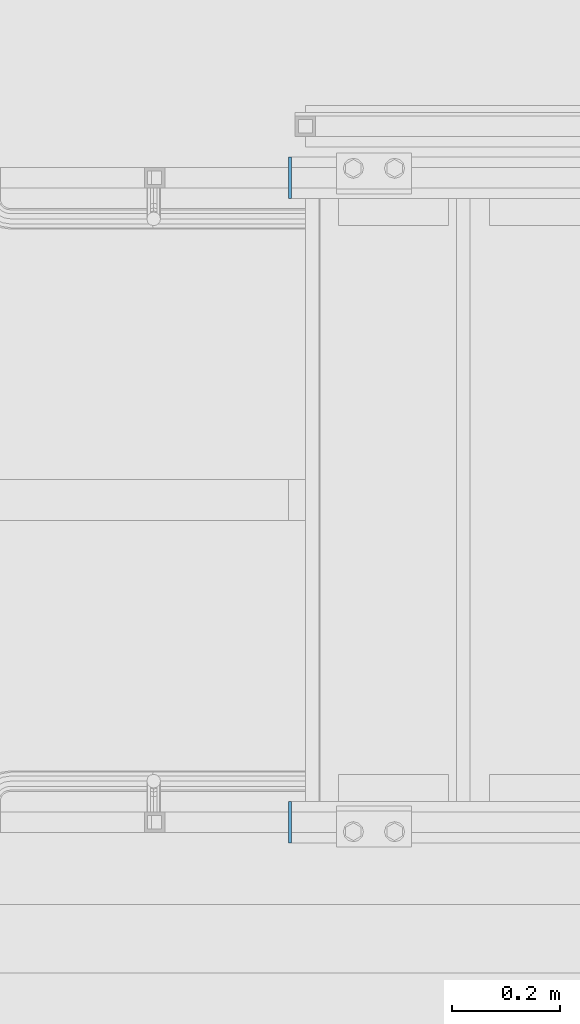
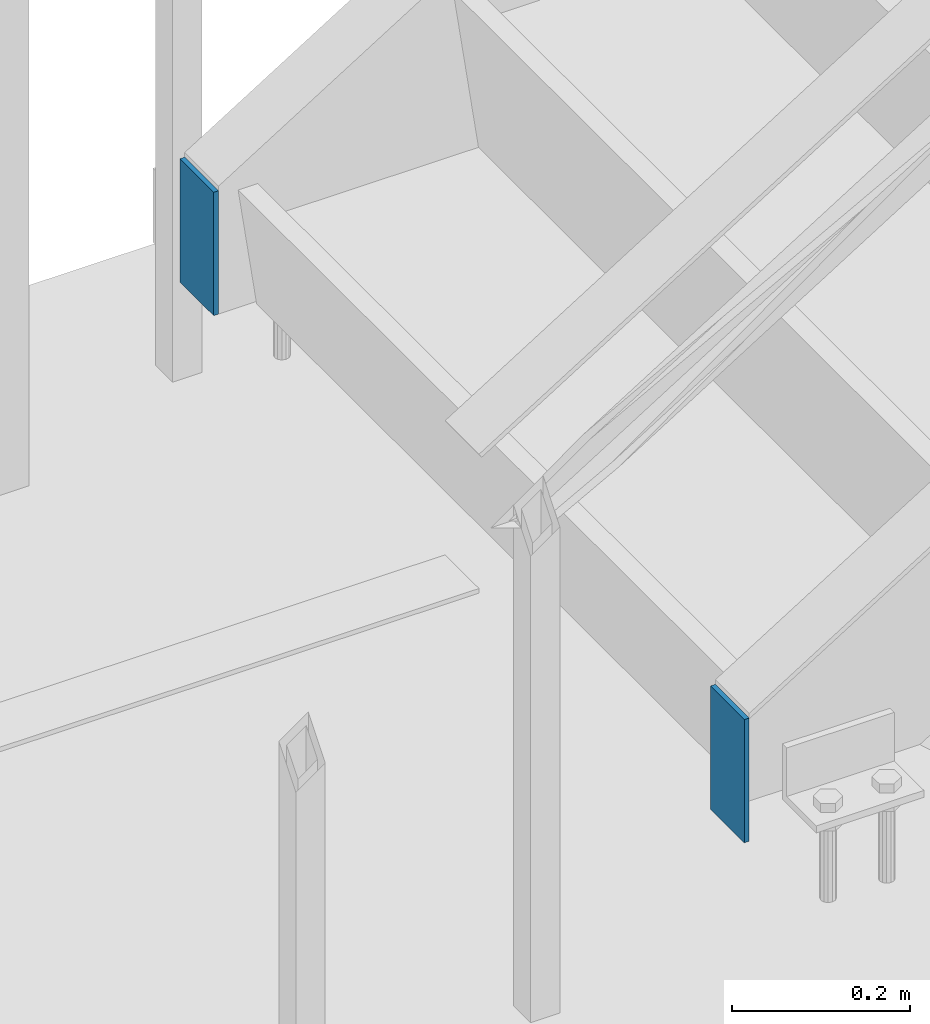
# One storey, part 1571 of 3843: 2 columns, 1 element without a shape of its own.
"""IFC2X3 building model written with IfcOpenShell, lengths in millimetres."""

from ifc_helpers import new_model, si_unit, frame, origin_with_axes, place, context, subcontext, project, spatial, faceted_brep, material, type_object, element, aggregate, save


model = new_model("IFC2X3")

# Units and contexts
model_context = context("Model", 3, precision=1e-05, world=origin_with_axes())
body_context = subcontext(model_context, "Body", "Model", "MODEL_VIEW")
ifc_project = project(units=[si_unit("LENGTHUNIT", "METRE", prefix="MILLI"), si_unit("AREAUNIT", "SQUARE_METRE"), si_unit("VOLUMEUNIT", "CUBIC_METRE"), si_unit("MASSUNIT", "GRAM", prefix="KILO"), si_unit("TIMEUNIT", "SECOND"), si_unit("PLANEANGLEUNIT", "RADIAN"), si_unit("SOLIDANGLEUNIT", "STERADIAN"), si_unit("THERMODYNAMICTEMPERATUREUNIT", "DEGREE_CELSIUS"), si_unit("LUMINOUSINTENSITYUNIT", "LUMEN")], contexts=[model_context])

# Site, building, storey
site_placement = place(None, origin_with_axes())
site = spatial("IfcSite", under=ifc_project, at=site_placement, CompositionType="ELEMENT")
building_placement = place(site_placement, origin_with_axes())
building = spatial("IfcBuilding", under=site, at=building_placement, Name="Undefined", CompositionType="ELEMENT")
storey_placement = place(building_placement, origin_with_axes())
storey = spatial("IfcBuildingStorey", under=building, at=storey_placement, Name="Undefined", CompositionType="ELEMENT", Elevation=0.0)

# Assembly, columns
assembly_placement = place(storey_placement, origin_with_axes())
assembly = element("IfcElementAssembly", 1, at=assembly_placement, inside=storey, Name="STAIR", AssemblyPlace="NOTDEFINED", PredefinedType="RIGID_FRAME")
ifc_material = material(Name="STEEL/A572-50")
column_type = type_object("IfcColumnType", PredefinedType="NOTDEFINED")
column_1_placement = place(assembly_placement, frame((31518.225, 90551.0000000096, 30492.7), z_axis=(0.0, -1.0, 0.0), x_axis=(0.0, 0.0, 1.0)))
column_1 = element("IfcColumn", 2, at=column_1_placement, type_object=column_type, material=ifc_material, Name="END", context=body_context, shape_type="Brep", body=[
    faceted_brep([(0.0, 3.17500000000291, -38.0999999999985), (0.0, 3.17500000000291, 38.0999999999985), (169.218719406756, 3.17499999999927, 38.1000000000058), (169.218719406756, 3.17499999999927, -38.1000000000058), (0.0, -3.17500000000291, 38.0999999999985), (169.218719406756, -3.17499999999927, 38.1000000000058), (0.0, -3.17500000000291, -38.0999999999985), (169.218719406756, -3.17499999999927, -38.1000000000058)], [[[0, 1, 2, 3]], [[1, 4, 5, 2]], [[4, 6, 7, 5]], [[6, 0, 3, 7]], [[5, 7, 3, 2]], [[6, 4, 1, 0]]]),
])
column_2_placement = place(assembly_placement, frame((31518.225, 89357.2000000009, 30492.7), z_axis=(0.0, -1.0, 0.0), x_axis=(0.0, 0.0, 1.0)))
column_2 = element("IfcColumn", 3, at=column_2_placement, type_object=column_type, material=ifc_material, Name="END", context=body_context, shape_type="Brep", body=[
    faceted_brep([(0.0, 3.17500000000291, -38.0999999999985), (0.0, 3.17500000000291, 38.0999999999985), (169.218719406756, 3.17499999999927, 38.1000000000058), (169.218719406756, 3.17499999999927, -38.1000000000058), (0.0, -3.17500000000291, 38.0999999999985), (169.218719406756, -3.17499999999927, 38.1000000000058), (0.0, -3.17500000000291, -38.0999999999985), (169.218719406756, -3.17499999999927, -38.1000000000058)], [[[0, 1, 2, 3]], [[1, 4, 5, 2]], [[4, 6, 7, 5]], [[6, 0, 3, 7]], [[5, 7, 3, 2]], [[6, 4, 1, 0]]]),
])
aggregate(assembly, [column_1, column_2])

save(model, "model.ifc")
